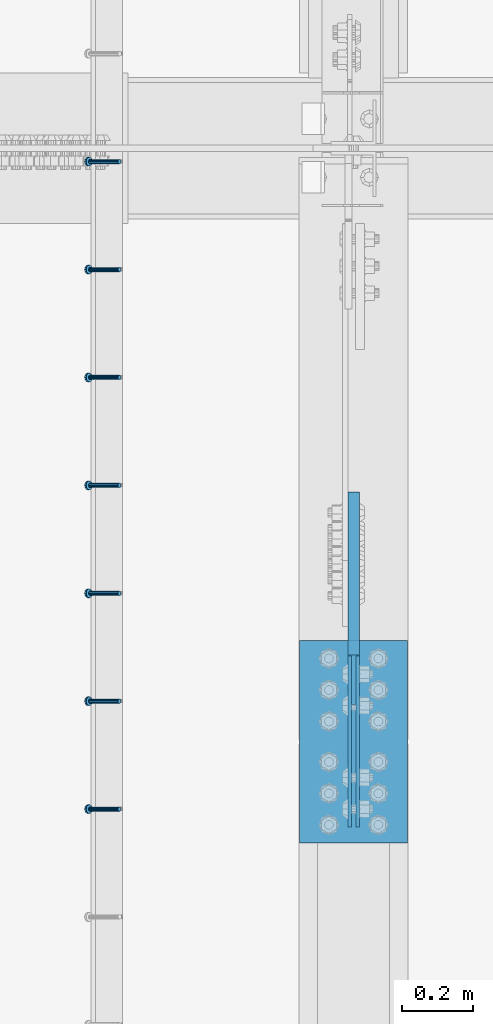
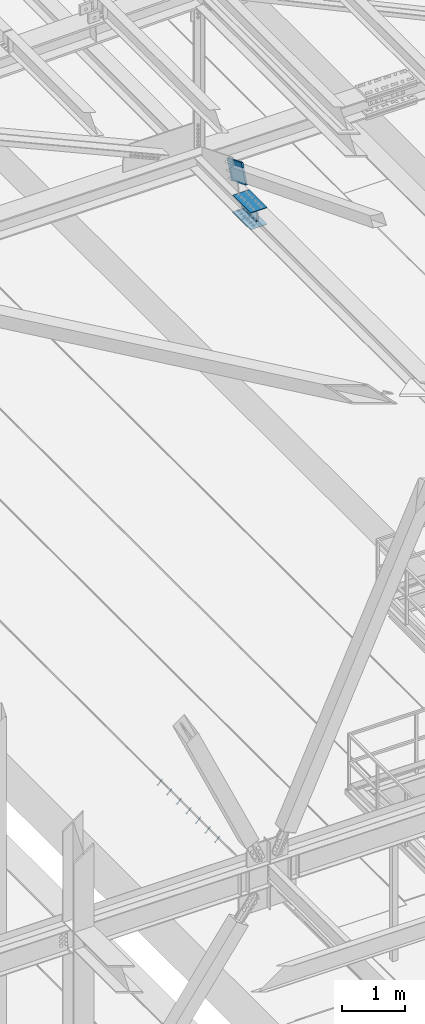
# One storey, part 2226 of 3843: 8 members, 4 beams, 3 elements without a shape of their own.
"""IFC2X3 building model written with IfcOpenShell, lengths in millimetres."""

from ifc_helpers import new_model, si_unit, frame, origin_with_axes, place, context, subcontext, project, spatial, faceted_brep, material, type_object, element, aggregate, save


model = new_model("IFC2X3")

# Units and contexts
model_context = context("Model", 3, precision=1e-05, world=origin_with_axes())
body_context = subcontext(model_context, "Body", "Model", "MODEL_VIEW")
ifc_project = project(units=[si_unit("LENGTHUNIT", "METRE", prefix="MILLI"), si_unit("AREAUNIT", "SQUARE_METRE"), si_unit("VOLUMEUNIT", "CUBIC_METRE"), si_unit("MASSUNIT", "GRAM", prefix="KILO"), si_unit("TIMEUNIT", "SECOND"), si_unit("PLANEANGLEUNIT", "RADIAN"), si_unit("SOLIDANGLEUNIT", "STERADIAN"), si_unit("THERMODYNAMICTEMPERATUREUNIT", "DEGREE_CELSIUS"), si_unit("LUMINOUSINTENSITYUNIT", "LUMEN")], contexts=[model_context])

# Site, building, storey
site_placement = place(None, origin_with_axes())
site = spatial("IfcSite", under=ifc_project, at=site_placement, CompositionType="ELEMENT")
building_placement = place(site_placement, origin_with_axes())
building = spatial("IfcBuilding", under=site, at=building_placement, Name="Undefined", CompositionType="ELEMENT")
storey_placement = place(building_placement, origin_with_axes())
storey = spatial("IfcBuildingStorey", under=building, at=storey_placement, Name="Undefined", CompositionType="ELEMENT", Elevation=0.0)

# Assembly, members
assembly_1_placement = place(storey_placement, origin_with_axes())
assembly_1 = element("IfcElementAssembly", 1, at=assembly_1_placement, inside=storey, Name="EMBED_ANGLE", AssemblyPlace="NOTDEFINED", PredefinedType="RIGID_FRAME")
ifc_material_1 = material(Name="STEEL/A108")
member_type_1 = type_object("IfcMemberType", PredefinedType="NOTDEFINED")
member_1_placement = place(assembly_1_placement, frame((48335.3741210938, 31978.6003845215, 30446.6625), z_axis=(0.0, -1.0, 0.0), x_axis=(-0.707106781186548, 0.0, -0.707106781186548)))
member_1 = element("IfcMember", 2, at=member_1_placement, type_object=member_type_1, material=ifc_material_1, Name="HEADED STUD ANCHOR", context=body_context, shape_type="Brep", body=[
    faceted_brep([(7.27595761418343e-12, -3.18000006675175, 5.5), (0.0, -5.49999999998363, 3.1800000667572), (118.110000000976, -5.49999999999091, 3.1800000667572), (118.110000000983, -3.18000006675175, 5.5), (0.0, -6.3499999046162, 0.0), (118.110000000968, -6.34999990461256, 0.0), (0.0, -5.49999999998363, -3.1800000667572), (118.110000000976, -5.49999999999091, -3.1800000667572), (7.27595761418343e-12, -3.18000006675175, -5.5), (118.110000000983, -3.18000006675175, -5.5), (7.27595761418343e-12, -1.81898940354586e-12, -6.34999990463257), (118.110000000968, -1.81898940354586e-12, -6.34999990463257), (0.0, 3.18000006675175, -5.5), (118.110000000968, 3.18000006674811, -5.5), (7.27595761418343e-12, 5.49999999998363, -3.1800000667572), (118.110000000983, 5.49999999998363, -3.1800000667572), (7.27595761418343e-12, 6.3499999046162, 0.0), (118.110000000976, 6.34999990461256, 0.0), (7.27595761418343e-12, 5.49999999998363, 3.1800000667572), (118.110000000983, 5.49999999998363, 3.1800000667572), (0.0, 3.18000006675175, 5.5), (118.110000000968, 3.18000006674811, 5.5), (7.27595761418343e-12, -1.81898940354586e-12, 6.34999990463257), (118.110000000968, -1.81898940354586e-12, 6.34999990463257), (120.650000000991, -10.9899997710909, 6.34999990463257), (120.650000000998, -6.34000015257152, 10.9899997711182), (120.650000000991, -12.6999998092379, 0.0), (120.650000000991, -10.9899997710909, -6.34999990463257), (120.650000000998, -6.34000015257152, -10.9899997711182), (120.650000000991, -1.81898940354586e-12, -12.6899995803833), (120.650000000991, 6.34000015257152, -10.9899997711182), (120.650000000998, 10.9899997710909, -6.34999990463257), (120.650000000991, 12.6999998092342, 0.0), (120.650000000998, 10.9899997710909, 6.34999990463257), (120.650000000991, 6.34000015257152, 10.9899997711182), (120.650000000991, -1.81898940354586e-12, 12.6899995803833), (127.000000001048, -10.9899997710945, 6.34999990463257), (127.000000001048, -6.34000015257152, 10.9899997711182), (127.000000001048, -12.6999998092342, 0.0), (127.000000001048, -10.9899997710945, -6.34999990463257), (127.000000001048, -6.34000015257152, -10.9899997711182), (127.000000001048, 1.81898940354586e-12, -12.6899995803833), (127.000000001048, 6.34000015256788, -10.9899997711182), (127.000000001048, 10.9899997710909, -6.34999990463257), (127.000000001048, 12.6999998092379, 0.0), (127.000000001048, 10.9899997710909, 6.34999990463257), (127.000000001048, 6.34000015256788, 10.9899997711182), (127.000000001048, 1.81898940354586e-12, 12.6899995803833)], [[[0, 1, 2, 3]], [[1, 4, 5, 2]], [[4, 6, 7, 5]], [[6, 8, 9, 7]], [[8, 10, 11, 9]], [[10, 12, 13, 11]], [[12, 14, 15, 13]], [[14, 16, 17, 15]], [[16, 18, 19, 17]], [[18, 20, 21, 19]], [[20, 22, 23, 21]], [[22, 0, 3, 23]], [[22, 20, 18, 16, 14, 12, 10, 8, 6, 4, 1, 0]], [[3, 2, 24, 25]], [[2, 5, 26, 24]], [[5, 7, 27, 26]], [[7, 9, 28, 27]], [[9, 11, 29, 28]], [[11, 13, 30, 29]], [[13, 15, 31, 30]], [[15, 17, 32, 31]], [[17, 19, 33, 32]], [[19, 21, 34, 33]], [[21, 23, 35, 34]], [[23, 3, 25, 35]], [[25, 24, 36, 37]], [[24, 26, 38, 36]], [[26, 27, 39, 38]], [[27, 28, 40, 39]], [[28, 29, 41, 40]], [[29, 30, 42, 41]], [[30, 31, 43, 42]], [[31, 32, 44, 43]], [[32, 33, 45, 44]], [[33, 34, 46, 45]], [[34, 35, 47, 46]], [[35, 25, 37, 47]], [[38, 39, 40, 41, 42, 43, 44, 45, 46, 47, 37, 36]]]),
])
member_2_placement = place(assembly_1_placement, frame((48335.3741210938, 32283.4003845215, 30446.6625), z_axis=(0.0, -1.0, 0.0), x_axis=(-0.707106781186548, 0.0, -0.707106781186548)))
member_2 = element("IfcMember", 3, at=member_2_placement, type_object=member_type_1, material=ifc_material_1, Name="HEADED STUD ANCHOR", context=body_context, shape_type="Brep", body=[
    faceted_brep([(7.27595761418343e-12, -3.18000006675175, 5.5), (0.0, -5.49999999998363, 3.1800000667572), (118.110000000976, -5.49999999999091, 3.1800000667572), (118.110000000983, -3.18000006675175, 5.5), (0.0, -6.3499999046162, 0.0), (118.110000000968, -6.34999990461256, 0.0), (0.0, -5.49999999998363, -3.1800000667572), (118.110000000976, -5.49999999999091, -3.1800000667572), (7.27595761418343e-12, -3.18000006675175, -5.5), (118.110000000983, -3.18000006675175, -5.5), (7.27595761418343e-12, -1.81898940354586e-12, -6.34999990463257), (118.110000000968, -1.81898940354586e-12, -6.34999990463257), (0.0, 3.18000006675175, -5.5), (118.110000000968, 3.18000006674811, -5.5), (7.27595761418343e-12, 5.49999999998363, -3.1800000667572), (118.110000000983, 5.49999999998363, -3.1800000667572), (7.27595761418343e-12, 6.3499999046162, 0.0), (118.110000000976, 6.34999990461256, 0.0), (7.27595761418343e-12, 5.49999999998363, 3.1800000667572), (118.110000000983, 5.49999999998363, 3.1800000667572), (0.0, 3.18000006675175, 5.5), (118.110000000968, 3.18000006674811, 5.5), (7.27595761418343e-12, -1.81898940354586e-12, 6.34999990463257), (118.110000000968, -1.81898940354586e-12, 6.34999990463257), (120.650000000991, -10.9899997710909, 6.34999990463257), (120.650000000998, -6.34000015257152, 10.9899997711182), (120.650000000991, -12.6999998092379, 0.0), (120.650000000991, -10.9899997710909, -6.34999990463257), (120.650000000998, -6.34000015257152, -10.9899997711182), (120.650000000991, -1.81898940354586e-12, -12.6899995803833), (120.650000000991, 6.34000015257152, -10.9899997711182), (120.650000000998, 10.9899997710909, -6.34999990463257), (120.650000000991, 12.6999998092342, 0.0), (120.650000000998, 10.9899997710909, 6.34999990463257), (120.650000000991, 6.34000015257152, 10.9899997711182), (120.650000000991, -1.81898940354586e-12, 12.6899995803833), (127.000000001048, -10.9899997710945, 6.34999990463257), (127.000000001048, -6.34000015257152, 10.9899997711182), (127.000000001048, -12.6999998092342, 0.0), (127.000000001048, -10.9899997710945, -6.34999990463257), (127.000000001048, -6.34000015257152, -10.9899997711182), (127.000000001048, 1.81898940354586e-12, -12.6899995803833), (127.000000001048, 6.34000015256788, -10.9899997711182), (127.000000001048, 10.9899997710909, -6.34999990463257), (127.000000001048, 12.6999998092379, 0.0), (127.000000001048, 10.9899997710909, 6.34999990463257), (127.000000001048, 6.34000015256788, 10.9899997711182), (127.000000001048, 1.81898940354586e-12, 12.6899995803833)], [[[0, 1, 2, 3]], [[1, 4, 5, 2]], [[4, 6, 7, 5]], [[6, 8, 9, 7]], [[8, 10, 11, 9]], [[10, 12, 13, 11]], [[12, 14, 15, 13]], [[14, 16, 17, 15]], [[16, 18, 19, 17]], [[18, 20, 21, 19]], [[20, 22, 23, 21]], [[22, 0, 3, 23]], [[22, 20, 18, 16, 14, 12, 10, 8, 6, 4, 1, 0]], [[3, 2, 24, 25]], [[2, 5, 26, 24]], [[5, 7, 27, 26]], [[7, 9, 28, 27]], [[9, 11, 29, 28]], [[11, 13, 30, 29]], [[13, 15, 31, 30]], [[15, 17, 32, 31]], [[17, 19, 33, 32]], [[19, 21, 34, 33]], [[21, 23, 35, 34]], [[23, 3, 25, 35]], [[25, 24, 36, 37]], [[24, 26, 38, 36]], [[26, 27, 39, 38]], [[27, 28, 40, 39]], [[28, 29, 41, 40]], [[29, 30, 42, 41]], [[30, 31, 43, 42]], [[31, 32, 44, 43]], [[32, 33, 45, 44]], [[33, 34, 46, 45]], [[34, 35, 47, 46]], [[35, 25, 37, 47]], [[38, 39, 40, 41, 42, 43, 44, 45, 46, 47, 37, 36]]]),
])
member_3_placement = place(assembly_1_placement, frame((48335.3741210938, 32588.2003845215, 30446.6625), z_axis=(0.0, -1.0, 0.0), x_axis=(-0.707106781186548, 0.0, -0.707106781186548)))
member_3 = element("IfcMember", 4, at=member_3_placement, type_object=member_type_1, material=ifc_material_1, Name="HEADED STUD ANCHOR", context=body_context, shape_type="Brep", body=[
    faceted_brep([(7.27595761418343e-12, -3.18000006675175, 5.5), (0.0, -5.49999999998363, 3.1800000667572), (118.110000000976, -5.49999999999091, 3.1800000667572), (118.110000000983, -3.18000006675175, 5.5), (0.0, -6.3499999046162, 0.0), (118.110000000968, -6.34999990461256, 0.0), (0.0, -5.49999999998363, -3.1800000667572), (118.110000000976, -5.49999999999091, -3.1800000667572), (7.27595761418343e-12, -3.18000006675175, -5.5), (118.110000000983, -3.18000006675175, -5.5), (7.27595761418343e-12, -1.81898940354586e-12, -6.34999990463257), (118.110000000968, -1.81898940354586e-12, -6.34999990463257), (0.0, 3.18000006675175, -5.5), (118.110000000968, 3.18000006674811, -5.5), (7.27595761418343e-12, 5.49999999998363, -3.1800000667572), (118.110000000983, 5.49999999998363, -3.1800000667572), (7.27595761418343e-12, 6.3499999046162, 0.0), (118.110000000976, 6.34999990461256, 0.0), (7.27595761418343e-12, 5.49999999998363, 3.1800000667572), (118.110000000983, 5.49999999998363, 3.1800000667572), (0.0, 3.18000006675175, 5.5), (118.110000000968, 3.18000006674811, 5.5), (7.27595761418343e-12, -1.81898940354586e-12, 6.34999990463257), (118.110000000968, -1.81898940354586e-12, 6.34999990463257), (120.650000000991, -10.9899997710909, 6.34999990463257), (120.650000000998, -6.34000015257152, 10.9899997711182), (120.650000000991, -12.6999998092379, 0.0), (120.650000000991, -10.9899997710909, -6.34999990463257), (120.650000000998, -6.34000015257152, -10.9899997711182), (120.650000000991, -1.81898940354586e-12, -12.6899995803833), (120.650000000991, 6.34000015257152, -10.9899997711182), (120.650000000998, 10.9899997710909, -6.34999990463257), (120.650000000991, 12.6999998092342, 0.0), (120.650000000998, 10.9899997710909, 6.34999990463257), (120.650000000991, 6.34000015257152, 10.9899997711182), (120.650000000991, -1.81898940354586e-12, 12.6899995803833), (127.000000001048, -10.9899997710945, 6.34999990463257), (127.000000001048, -6.34000015257152, 10.9899997711182), (127.000000001048, -12.6999998092342, 0.0), (127.000000001048, -10.9899997710945, -6.34999990463257), (127.000000001048, -6.34000015257152, -10.9899997711182), (127.000000001048, 1.81898940354586e-12, -12.6899995803833), (127.000000001048, 6.34000015256788, -10.9899997711182), (127.000000001048, 10.9899997710909, -6.34999990463257), (127.000000001048, 12.6999998092379, 0.0), (127.000000001048, 10.9899997710909, 6.34999990463257), (127.000000001048, 6.34000015256788, 10.9899997711182), (127.000000001048, 1.81898940354586e-12, 12.6899995803833)], [[[0, 1, 2, 3]], [[1, 4, 5, 2]], [[4, 6, 7, 5]], [[6, 8, 9, 7]], [[8, 10, 11, 9]], [[10, 12, 13, 11]], [[12, 14, 15, 13]], [[14, 16, 17, 15]], [[16, 18, 19, 17]], [[18, 20, 21, 19]], [[20, 22, 23, 21]], [[22, 0, 3, 23]], [[22, 20, 18, 16, 14, 12, 10, 8, 6, 4, 1, 0]], [[3, 2, 24, 25]], [[2, 5, 26, 24]], [[5, 7, 27, 26]], [[7, 9, 28, 27]], [[9, 11, 29, 28]], [[11, 13, 30, 29]], [[13, 15, 31, 30]], [[15, 17, 32, 31]], [[17, 19, 33, 32]], [[19, 21, 34, 33]], [[21, 23, 35, 34]], [[23, 3, 25, 35]], [[25, 24, 36, 37]], [[24, 26, 38, 36]], [[26, 27, 39, 38]], [[27, 28, 40, 39]], [[28, 29, 41, 40]], [[29, 30, 42, 41]], [[30, 31, 43, 42]], [[31, 32, 44, 43]], [[32, 33, 45, 44]], [[33, 34, 46, 45]], [[34, 35, 47, 46]], [[35, 25, 37, 47]], [[38, 39, 40, 41, 42, 43, 44, 45, 46, 47, 37, 36]]]),
])
member_4_placement = place(assembly_1_placement, frame((48335.3741210938, 32893.0003845215, 30446.6625), z_axis=(0.0, -1.0, 0.0), x_axis=(-0.707106781186548, 0.0, -0.707106781186548)))
member_4 = element("IfcMember", 5, at=member_4_placement, type_object=member_type_1, material=ifc_material_1, Name="HEADED STUD ANCHOR", context=body_context, shape_type="Brep", body=[
    faceted_brep([(7.27595761418343e-12, -3.18000006675175, 5.5), (0.0, -5.49999999998363, 3.1800000667572), (118.110000000976, -5.49999999999091, 3.1800000667572), (118.110000000983, -3.18000006675175, 5.5), (0.0, -6.3499999046162, 0.0), (118.110000000968, -6.34999990461256, 0.0), (0.0, -5.49999999998363, -3.1800000667572), (118.110000000976, -5.49999999999091, -3.1800000667572), (7.27595761418343e-12, -3.18000006675175, -5.5), (118.110000000983, -3.18000006675175, -5.5), (7.27595761418343e-12, -1.81898940354586e-12, -6.34999990463257), (118.110000000968, -1.81898940354586e-12, -6.34999990463257), (0.0, 3.18000006675175, -5.5), (118.110000000968, 3.18000006674811, -5.5), (7.27595761418343e-12, 5.49999999998363, -3.1800000667572), (118.110000000983, 5.49999999998363, -3.1800000667572), (7.27595761418343e-12, 6.3499999046162, 0.0), (118.110000000976, 6.34999990461256, 0.0), (7.27595761418343e-12, 5.49999999998363, 3.1800000667572), (118.110000000983, 5.49999999998363, 3.1800000667572), (0.0, 3.18000006675175, 5.5), (118.110000000968, 3.18000006674811, 5.5), (7.27595761418343e-12, -1.81898940354586e-12, 6.34999990463257), (118.110000000968, -1.81898940354586e-12, 6.34999990463257), (120.650000000991, -10.9899997710909, 6.34999990463257), (120.650000000998, -6.34000015257152, 10.9899997711182), (120.650000000991, -12.6999998092379, 0.0), (120.650000000991, -10.9899997710909, -6.34999990463257), (120.650000000998, -6.34000015257152, -10.9899997711182), (120.650000000991, -1.81898940354586e-12, -12.6899995803833), (120.650000000991, 6.34000015257152, -10.9899997711182), (120.650000000998, 10.9899997710909, -6.34999990463257), (120.650000000991, 12.6999998092342, 0.0), (120.650000000998, 10.9899997710909, 6.34999990463257), (120.650000000991, 6.34000015257152, 10.9899997711182), (120.650000000991, -1.81898940354586e-12, 12.6899995803833), (127.000000001048, -10.9899997710945, 6.34999990463257), (127.000000001048, -6.34000015257152, 10.9899997711182), (127.000000001048, -12.6999998092342, 0.0), (127.000000001048, -10.9899997710945, -6.34999990463257), (127.000000001048, -6.34000015257152, -10.9899997711182), (127.000000001048, 1.81898940354586e-12, -12.6899995803833), (127.000000001048, 6.34000015256788, -10.9899997711182), (127.000000001048, 10.9899997710909, -6.34999990463257), (127.000000001048, 12.6999998092379, 0.0), (127.000000001048, 10.9899997710909, 6.34999990463257), (127.000000001048, 6.34000015256788, 10.9899997711182), (127.000000001048, 1.81898940354586e-12, 12.6899995803833)], [[[0, 1, 2, 3]], [[1, 4, 5, 2]], [[4, 6, 7, 5]], [[6, 8, 9, 7]], [[8, 10, 11, 9]], [[10, 12, 13, 11]], [[12, 14, 15, 13]], [[14, 16, 17, 15]], [[16, 18, 19, 17]], [[18, 20, 21, 19]], [[20, 22, 23, 21]], [[22, 0, 3, 23]], [[22, 20, 18, 16, 14, 12, 10, 8, 6, 4, 1, 0]], [[3, 2, 24, 25]], [[2, 5, 26, 24]], [[5, 7, 27, 26]], [[7, 9, 28, 27]], [[9, 11, 29, 28]], [[11, 13, 30, 29]], [[13, 15, 31, 30]], [[15, 17, 32, 31]], [[17, 19, 33, 32]], [[19, 21, 34, 33]], [[21, 23, 35, 34]], [[23, 3, 25, 35]], [[25, 24, 36, 37]], [[24, 26, 38, 36]], [[26, 27, 39, 38]], [[27, 28, 40, 39]], [[28, 29, 41, 40]], [[29, 30, 42, 41]], [[30, 31, 43, 42]], [[31, 32, 44, 43]], [[32, 33, 45, 44]], [[33, 34, 46, 45]], [[34, 35, 47, 46]], [[35, 25, 37, 47]], [[38, 39, 40, 41, 42, 43, 44, 45, 46, 47, 37, 36]]]),
])
member_5_placement = place(assembly_1_placement, frame((48335.3741210938, 33197.8003845215, 30446.6625), z_axis=(0.0, -1.0, 0.0), x_axis=(-0.707106781186548, 0.0, -0.707106781186548)))
member_5 = element("IfcMember", 6, at=member_5_placement, type_object=member_type_1, material=ifc_material_1, Name="HEADED STUD ANCHOR", context=body_context, shape_type="Brep", body=[
    faceted_brep([(7.27595761418343e-12, -3.18000006675175, 5.5), (0.0, -5.49999999998363, 3.1800000667572), (118.110000000976, -5.49999999999091, 3.1800000667572), (118.110000000983, -3.18000006675175, 5.5), (0.0, -6.3499999046162, 0.0), (118.110000000968, -6.34999990461256, 0.0), (0.0, -5.49999999998363, -3.1800000667572), (118.110000000976, -5.49999999999091, -3.1800000667572), (7.27595761418343e-12, -3.18000006675175, -5.5), (118.110000000983, -3.18000006675175, -5.5), (7.27595761418343e-12, -1.81898940354586e-12, -6.34999990463257), (118.110000000968, -1.81898940354586e-12, -6.34999990463257), (0.0, 3.18000006675175, -5.5), (118.110000000968, 3.18000006674811, -5.5), (7.27595761418343e-12, 5.49999999998363, -3.1800000667572), (118.110000000983, 5.49999999998363, -3.1800000667572), (7.27595761418343e-12, 6.3499999046162, 0.0), (118.110000000976, 6.34999990461256, 0.0), (7.27595761418343e-12, 5.49999999998363, 3.1800000667572), (118.110000000983, 5.49999999998363, 3.1800000667572), (0.0, 3.18000006675175, 5.5), (118.110000000968, 3.18000006674811, 5.5), (7.27595761418343e-12, -1.81898940354586e-12, 6.34999990463257), (118.110000000968, -1.81898940354586e-12, 6.34999990463257), (120.650000000991, -10.9899997710909, 6.34999990463257), (120.650000000998, -6.34000015257152, 10.9899997711182), (120.650000000991, -12.6999998092379, 0.0), (120.650000000991, -10.9899997710909, -6.34999990463257), (120.650000000998, -6.34000015257152, -10.9899997711182), (120.650000000991, -1.81898940354586e-12, -12.6899995803833), (120.650000000991, 6.34000015257152, -10.9899997711182), (120.650000000998, 10.9899997710909, -6.34999990463257), (120.650000000991, 12.6999998092342, 0.0), (120.650000000998, 10.9899997710909, 6.34999990463257), (120.650000000991, 6.34000015257152, 10.9899997711182), (120.650000000991, -1.81898940354586e-12, 12.6899995803833), (127.000000001048, -10.9899997710945, 6.34999990463257), (127.000000001048, -6.34000015257152, 10.9899997711182), (127.000000001048, -12.6999998092342, 0.0), (127.000000001048, -10.9899997710945, -6.34999990463257), (127.000000001048, -6.34000015257152, -10.9899997711182), (127.000000001048, 1.81898940354586e-12, -12.6899995803833), (127.000000001048, 6.34000015256788, -10.9899997711182), (127.000000001048, 10.9899997710909, -6.34999990463257), (127.000000001048, 12.6999998092379, 0.0), (127.000000001048, 10.9899997710909, 6.34999990463257), (127.000000001048, 6.34000015256788, 10.9899997711182), (127.000000001048, 1.81898940354586e-12, 12.6899995803833)], [[[0, 1, 2, 3]], [[1, 4, 5, 2]], [[4, 6, 7, 5]], [[6, 8, 9, 7]], [[8, 10, 11, 9]], [[10, 12, 13, 11]], [[12, 14, 15, 13]], [[14, 16, 17, 15]], [[16, 18, 19, 17]], [[18, 20, 21, 19]], [[20, 22, 23, 21]], [[22, 0, 3, 23]], [[22, 20, 18, 16, 14, 12, 10, 8, 6, 4, 1, 0]], [[3, 2, 24, 25]], [[2, 5, 26, 24]], [[5, 7, 27, 26]], [[7, 9, 28, 27]], [[9, 11, 29, 28]], [[11, 13, 30, 29]], [[13, 15, 31, 30]], [[15, 17, 32, 31]], [[17, 19, 33, 32]], [[19, 21, 34, 33]], [[21, 23, 35, 34]], [[23, 3, 25, 35]], [[25, 24, 36, 37]], [[24, 26, 38, 36]], [[26, 27, 39, 38]], [[27, 28, 40, 39]], [[28, 29, 41, 40]], [[29, 30, 42, 41]], [[30, 31, 43, 42]], [[31, 32, 44, 43]], [[32, 33, 45, 44]], [[33, 34, 46, 45]], [[34, 35, 47, 46]], [[35, 25, 37, 47]], [[38, 39, 40, 41, 42, 43, 44, 45, 46, 47, 37, 36]]]),
])
member_6_placement = place(assembly_1_placement, frame((48335.3741210938, 33502.6003845215, 30446.6625), z_axis=(0.0, -1.0, 0.0), x_axis=(-0.707106781186548, 0.0, -0.707106781186548)))
member_6 = element("IfcMember", 7, at=member_6_placement, type_object=member_type_1, material=ifc_material_1, Name="HEADED STUD ANCHOR", context=body_context, shape_type="Brep", body=[
    faceted_brep([(7.27595761418343e-12, -3.18000006675175, 5.5), (0.0, -5.49999999998363, 3.1800000667572), (118.110000000976, -5.49999999999091, 3.1800000667572), (118.110000000983, -3.18000006675175, 5.5), (0.0, -6.3499999046162, 0.0), (118.110000000968, -6.34999990461256, 0.0), (0.0, -5.49999999998363, -3.1800000667572), (118.110000000976, -5.49999999999091, -3.1800000667572), (7.27595761418343e-12, -3.18000006675175, -5.5), (118.110000000983, -3.18000006675175, -5.5), (7.27595761418343e-12, -1.81898940354586e-12, -6.34999990463257), (118.110000000968, -1.81898940354586e-12, -6.34999990463257), (0.0, 3.18000006675175, -5.5), (118.110000000968, 3.18000006674811, -5.5), (7.27595761418343e-12, 5.49999999998363, -3.1800000667572), (118.110000000983, 5.49999999998363, -3.1800000667572), (7.27595761418343e-12, 6.3499999046162, 0.0), (118.110000000976, 6.34999990461256, 0.0), (7.27595761418343e-12, 5.49999999998363, 3.1800000667572), (118.110000000983, 5.49999999998363, 3.1800000667572), (0.0, 3.18000006675175, 5.5), (118.110000000968, 3.18000006674811, 5.5), (7.27595761418343e-12, -1.81898940354586e-12, 6.34999990463257), (118.110000000968, -1.81898940354586e-12, 6.34999990463257), (120.650000000991, -10.9899997710909, 6.34999990463257), (120.650000000998, -6.34000015257152, 10.9899997711182), (120.650000000991, -12.6999998092379, 0.0), (120.650000000991, -10.9899997710909, -6.34999990463257), (120.650000000998, -6.34000015257152, -10.9899997711182), (120.650000000991, -1.81898940354586e-12, -12.6899995803833), (120.650000000991, 6.34000015257152, -10.9899997711182), (120.650000000998, 10.9899997710909, -6.34999990463257), (120.650000000991, 12.6999998092342, 0.0), (120.650000000998, 10.9899997710909, 6.34999990463257), (120.650000000991, 6.34000015257152, 10.9899997711182), (120.650000000991, -1.81898940354586e-12, 12.6899995803833), (127.000000001048, -10.9899997710945, 6.34999990463257), (127.000000001048, -6.34000015257152, 10.9899997711182), (127.000000001048, -12.6999998092342, 0.0), (127.000000001048, -10.9899997710945, -6.34999990463257), (127.000000001048, -6.34000015257152, -10.9899997711182), (127.000000001048, 1.81898940354586e-12, -12.6899995803833), (127.000000001048, 6.34000015256788, -10.9899997711182), (127.000000001048, 10.9899997710909, -6.34999990463257), (127.000000001048, 12.6999998092379, 0.0), (127.000000001048, 10.9899997710909, 6.34999990463257), (127.000000001048, 6.34000015256788, 10.9899997711182), (127.000000001048, 1.81898940354586e-12, 12.6899995803833)], [[[0, 1, 2, 3]], [[1, 4, 5, 2]], [[4, 6, 7, 5]], [[6, 8, 9, 7]], [[8, 10, 11, 9]], [[10, 12, 13, 11]], [[12, 14, 15, 13]], [[14, 16, 17, 15]], [[16, 18, 19, 17]], [[18, 20, 21, 19]], [[20, 22, 23, 21]], [[22, 0, 3, 23]], [[22, 20, 18, 16, 14, 12, 10, 8, 6, 4, 1, 0]], [[3, 2, 24, 25]], [[2, 5, 26, 24]], [[5, 7, 27, 26]], [[7, 9, 28, 27]], [[9, 11, 29, 28]], [[11, 13, 30, 29]], [[13, 15, 31, 30]], [[15, 17, 32, 31]], [[17, 19, 33, 32]], [[19, 21, 34, 33]], [[21, 23, 35, 34]], [[23, 3, 25, 35]], [[25, 24, 36, 37]], [[24, 26, 38, 36]], [[26, 27, 39, 38]], [[27, 28, 40, 39]], [[28, 29, 41, 40]], [[29, 30, 42, 41]], [[30, 31, 43, 42]], [[31, 32, 44, 43]], [[32, 33, 45, 44]], [[33, 34, 46, 45]], [[34, 35, 47, 46]], [[35, 25, 37, 47]], [[38, 39, 40, 41, 42, 43, 44, 45, 46, 47, 37, 36]]]),
])
member_7_placement = place(assembly_1_placement, frame((48335.3741210938, 33807.4003845215, 30446.6625), z_axis=(0.0, -1.0, 0.0), x_axis=(-0.707106781186548, 0.0, -0.707106781186548)))
member_7 = element("IfcMember", 8, at=member_7_placement, type_object=member_type_1, material=ifc_material_1, Name="HEADED STUD ANCHOR", context=body_context, shape_type="Brep", body=[
    faceted_brep([(7.27595761418343e-12, -3.18000006675175, 5.5), (0.0, -5.49999999998363, 3.1800000667572), (118.110000000976, -5.49999999999091, 3.1800000667572), (118.110000000983, -3.18000006675175, 5.5), (0.0, -6.3499999046162, 0.0), (118.110000000968, -6.34999990461256, 0.0), (0.0, -5.49999999998363, -3.1800000667572), (118.110000000976, -5.49999999999091, -3.1800000667572), (7.27595761418343e-12, -3.18000006675175, -5.5), (118.110000000983, -3.18000006675175, -5.5), (7.27595761418343e-12, -1.81898940354586e-12, -6.34999990463257), (118.110000000968, -1.81898940354586e-12, -6.34999990463257), (0.0, 3.18000006675175, -5.5), (118.110000000968, 3.18000006674811, -5.5), (7.27595761418343e-12, 5.49999999998363, -3.1800000667572), (118.110000000983, 5.49999999998363, -3.1800000667572), (7.27595761418343e-12, 6.3499999046162, 0.0), (118.110000000976, 6.34999990461256, 0.0), (7.27595761418343e-12, 5.49999999998363, 3.1800000667572), (118.110000000983, 5.49999999998363, 3.1800000667572), (0.0, 3.18000006675175, 5.5), (118.110000000968, 3.18000006674811, 5.5), (7.27595761418343e-12, -1.81898940354586e-12, 6.34999990463257), (118.110000000968, -1.81898940354586e-12, 6.34999990463257), (120.650000000991, -10.9899997710909, 6.34999990463257), (120.650000000998, -6.34000015257152, 10.9899997711182), (120.650000000991, -12.6999998092379, 0.0), (120.650000000991, -10.9899997710909, -6.34999990463257), (120.650000000998, -6.34000015257152, -10.9899997711182), (120.650000000991, -1.81898940354586e-12, -12.6899995803833), (120.650000000991, 6.34000015257152, -10.9899997711182), (120.650000000998, 10.9899997710909, -6.34999990463257), (120.650000000991, 12.6999998092342, 0.0), (120.650000000998, 10.9899997710909, 6.34999990463257), (120.650000000991, 6.34000015257152, 10.9899997711182), (120.650000000991, -1.81898940354586e-12, 12.6899995803833), (127.000000001048, -10.9899997710945, 6.34999990463257), (127.000000001048, -6.34000015257152, 10.9899997711182), (127.000000001048, -12.6999998092342, 0.0), (127.000000001048, -10.9899997710945, -6.34999990463257), (127.000000001048, -6.34000015257152, -10.9899997711182), (127.000000001048, 1.81898940354586e-12, -12.6899995803833), (127.000000001048, 6.34000015256788, -10.9899997711182), (127.000000001048, 10.9899997710909, -6.34999990463257), (127.000000001048, 12.6999998092379, 0.0), (127.000000001048, 10.9899997710909, 6.34999990463257), (127.000000001048, 6.34000015256788, 10.9899997711182), (127.000000001048, 1.81898940354586e-12, 12.6899995803833)], [[[0, 1, 2, 3]], [[1, 4, 5, 2]], [[4, 6, 7, 5]], [[6, 8, 9, 7]], [[8, 10, 11, 9]], [[10, 12, 13, 11]], [[12, 14, 15, 13]], [[14, 16, 17, 15]], [[16, 18, 19, 17]], [[18, 20, 21, 19]], [[20, 22, 23, 21]], [[22, 0, 3, 23]], [[22, 20, 18, 16, 14, 12, 10, 8, 6, 4, 1, 0]], [[3, 2, 24, 25]], [[2, 5, 26, 24]], [[5, 7, 27, 26]], [[7, 9, 28, 27]], [[9, 11, 29, 28]], [[11, 13, 30, 29]], [[13, 15, 31, 30]], [[15, 17, 32, 31]], [[17, 19, 33, 32]], [[19, 21, 34, 33]], [[21, 23, 35, 34]], [[23, 3, 25, 35]], [[25, 24, 36, 37]], [[24, 26, 38, 36]], [[26, 27, 39, 38]], [[27, 28, 40, 39]], [[28, 29, 41, 40]], [[29, 30, 42, 41]], [[30, 31, 43, 42]], [[31, 32, 44, 43]], [[32, 33, 45, 44]], [[33, 34, 46, 45]], [[34, 35, 47, 46]], [[35, 25, 37, 47]], [[38, 39, 40, 41, 42, 43, 44, 45, 46, 47, 37, 36]]]),
])
aggregate(assembly_1, [member_1, member_2, member_3, member_4, member_5, member_6, member_7])

# Assembly, beams
assembly_2_placement = place(storey_placement, origin_with_axes())
assembly_2 = element("IfcElementAssembly", 9, at=assembly_2_placement, inside=storey, Name="BEAM", AssemblyPlace="NOTDEFINED", PredefinedType="RIGID_FRAME")
ifc_material_2 = material(Name="STEEL/A572-50")
beam_type_1 = type_object("IfcBeamType", PredefinedType="NOTDEFINED")
beam_1_placement = place(assembly_2_placement, frame((48985.4875, 32410.3999359168, 42251.501105042), z_axis=(0.0, -0.000728692999644406, 0.999999734503221), x_axis=(0.0, -0.999999734503221, -0.000728692999635592)))
beam_1 = element("IfcBeam", 10, at=beam_1_placement, type_object=beam_type_1, material=ifc_material_2, Name="PLATE", context=body_context, shape_type="Brep", body=[
    faceted_brep([(-4.65661287307739e-10, 4.76249999999709, -88.9000000002779), (0.0, 4.76249999999709, 88.9000015258789), (482.600000007384, 4.76249999999709, 88.9000000010856), (482.60000000638, 4.76249999999709, -88.8999999994776), (0.0, -4.76249999999709, 88.9000015258789), (482.600000007384, -4.76249999999709, 88.9000000010856), (-4.65661287307739e-10, -4.76249999999709, -88.9000000002779), (482.60000000638, -4.76249999999709, -88.8999999994776)], [[[0, 1, 2, 3]], [[1, 4, 5, 2]], [[4, 6, 7, 5]], [[6, 0, 3, 7]], [[5, 7, 3, 2]], [[6, 4, 1, 0]]]),
])
beam_2_placement = place(assembly_2_placement, frame((49007.7125, 32410.3999359168, 42251.501105042), z_axis=(0.0, -0.000728692999644406, 0.999999734503221), x_axis=(0.0, -0.999999734503221, -0.000728692999635592)))
beam_2 = element("IfcBeam", 11, at=beam_2_placement, type_object=beam_type_1, material=ifc_material_2, Name="PLATE", context=body_context, shape_type="Brep", body=[
    faceted_brep([(-4.65661287307739e-10, 4.76249999999709, -88.9000000002779), (0.0, 4.76249999999709, 88.9000015258789), (482.600000007384, 4.76249999999709, 88.9000000010856), (482.60000000638, 4.76249999999709, -88.8999999994776), (0.0, -4.76249999999709, 88.9000015258789), (482.600000007384, -4.76249999999709, 88.9000000010856), (-4.65661287307739e-10, -4.76249999999709, -88.9000000002779), (482.60000000638, -4.76249999999709, -88.8999999994776)], [[[0, 1, 2, 3]], [[1, 4, 5, 2]], [[4, 6, 7, 5]], [[6, 0, 3, 7]], [[5, 7, 3, 2]], [[6, 4, 1, 0]]]),
])
beam_type_2 = type_object("IfcBeamType", PredefinedType="NOTDEFINED")
beam_3_placement = place(assembly_2_placement, frame((48996.6, 32454.9679177294, 42089.6085384405), z_axis=(-1.0, 0.0, 0.0), x_axis=(0.0, -0.999999734503221, -0.000728692999635592)))
beam_3 = element("IfcBeam", 12, at=beam_3_placement, type_object=beam_type_2, material=ifc_material_2, Name="PLATE", context=body_context, shape_type="Brep", body=[
    faceted_brep([(2.91038304567337e-11, 4.76250000001892, -152.400000000001), (2.91038304567337e-11, 4.76250000001892, 152.400000000001), (571.500000008222, 4.76250000096479, 152.400000000001), (571.500000008222, 4.76250000096479, -152.400000000001), (-2.91038304567337e-11, -4.76250000001164, 152.400000000001), (571.500000008164, -4.76249999906577, 152.400000000001), (-2.91038304567337e-11, -4.76250000001164, -152.400000000001), (571.500000008164, -4.76249999906577, -152.400000000001)], [[[0, 1, 2, 3]], [[1, 4, 5, 2]], [[4, 6, 7, 5]], [[6, 0, 3, 7]], [[5, 7, 3, 2]], [[6, 4, 1, 0]]]),
])
beam_4_placement = place(assembly_2_placement, frame((48996.6, 32454.7319305015, 42413.4584532494), z_axis=(-1.0, 0.0, 0.0), x_axis=(0.0, -0.999999734503221, -0.000728692999635592)))
beam_4 = element("IfcBeam", 13, at=beam_4_placement, type_object=beam_type_2, material=ifc_material_2, Name="PLATE", context=body_context, shape_type="Brep", body=[
    faceted_brep([(2.91038304567337e-11, 4.76250000001892, -152.400000000001), (2.91038304567337e-11, 4.76250000001892, 152.400000000001), (571.500000008222, 4.76250000096479, 152.400000000001), (571.500000008222, 4.76250000096479, -152.400000000001), (-2.91038304567337e-11, -4.76250000001164, 152.400000000001), (571.500000008164, -4.76249999906577, 152.400000000001), (-2.91038304567337e-11, -4.76250000001164, -152.400000000001), (571.500000008164, -4.76249999906577, -152.400000000001)], [[[0, 1, 2, 3]], [[1, 4, 5, 2]], [[4, 6, 7, 5]], [[6, 0, 3, 7]], [[5, 7, 3, 2]], [[6, 4, 1, 0]]]),
])
aggregate(assembly_2, [beam_1, beam_3, beam_4, beam_2])

# Assembly, member
assembly_3_placement = place(storey_placement, origin_with_axes())
assembly_3 = element("IfcElementAssembly", 14, at=assembly_3_placement, inside=storey, AssemblyPlace="NOTDEFINED", PredefinedType="RIGID_FRAME")
member_type_2 = type_object("IfcMemberType", PredefinedType="NOTDEFINED")
member_8_placement = place(assembly_3_placement, frame((48996.6, 32804.8829652033, 42661.9484433697), z_axis=(0.0, 0.366107655820117, 0.930572503542791), x_axis=(0.0, -0.930572503542789, 0.366107655820123)))
member_8 = element("IfcMember", 15, at=member_8_placement, type_object=member_type_2, material=ifc_material_2, Name="PLATE", context=body_context, shape_type="Brep", body=[
    faceted_brep([(3.56521923094988e-10, 15.875, -190.500000000146), (-3.61978891305625e-10, 15.875, 190.500000000153), (495.299999995012, 15.875, 190.500000001084), (495.299999995726, 15.875, -190.499999999221), (-3.61978891305625e-10, -15.875, 190.500000000153), (495.299999995012, -15.875, 190.500000001084), (3.56521923094988e-10, -15.875, -190.500000000146), (495.299999995726, -15.875, -190.499999999221)], [[[0, 1, 2, 3]], [[1, 4, 5, 2]], [[4, 6, 7, 5]], [[6, 0, 3, 7]], [[5, 7, 3, 2]], [[6, 4, 1, 0]]]),
])
aggregate(assembly_3, [member_8])

save(model, "model.ifc")
